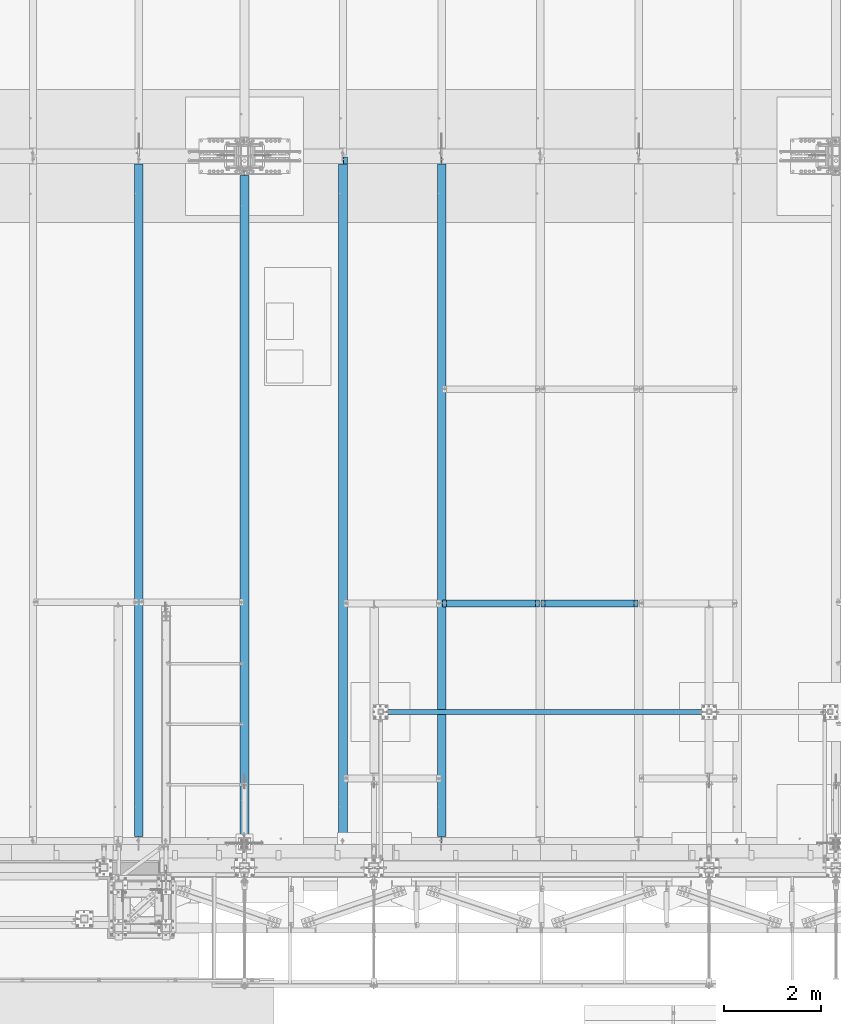
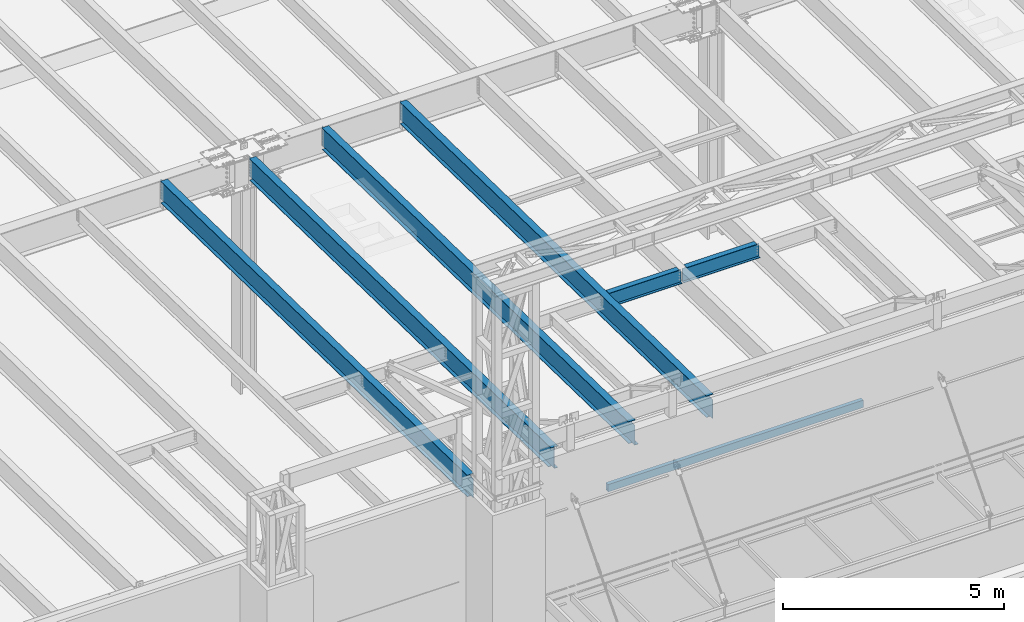
# One storey, part 1059 of 1763: 7 beams, 7 elements without a shape of their own.
"""IFC2X3 building model written with IfcOpenShell, lengths in millimetres."""

from ifc_helpers import new_model, si_unit, frame, origin_with_axes, place, context, subcontext, project, spatial, faceted_brep, material, type_object, element, aggregate, save


model = new_model("IFC2X3")

# Units and contexts
model_context = context("Model", 3, precision=1e-05, world=origin_with_axes())
body_context = subcontext(model_context, "Body", "Model", "MODEL_VIEW")
ifc_project = project(units=[si_unit("LENGTHUNIT", "METRE", prefix="MILLI"), si_unit("AREAUNIT", "SQUARE_METRE"), si_unit("VOLUMEUNIT", "CUBIC_METRE"), si_unit("MASSUNIT", "GRAM", prefix="KILO"), si_unit("TIMEUNIT", "SECOND"), si_unit("PLANEANGLEUNIT", "RADIAN"), si_unit("SOLIDANGLEUNIT", "STERADIAN"), si_unit("THERMODYNAMICTEMPERATUREUNIT", "DEGREE_CELSIUS"), si_unit("LUMINOUSINTENSITYUNIT", "LUMEN")], contexts=[model_context])

# Site, building, storey
site_placement = place(None, origin_with_axes())
site = spatial("IfcSite", under=ifc_project, at=site_placement, CompositionType="ELEMENT")
building_placement = place(site_placement, origin_with_axes())
building = spatial("IfcBuilding", under=site, at=building_placement, Name="Undefined", CompositionType="ELEMENT")
storey_placement = place(building_placement, origin_with_axes())
storey = spatial("IfcBuildingStorey", under=building, at=storey_placement, Name="Undefined", CompositionType="ELEMENT", Elevation=0.0)

# Assembly, beam
assembly_1_placement = place(storey_placement, origin_with_axes())
assembly_1 = element("IfcElementAssembly", 1, at=assembly_1_placement, inside=storey, Name="BEAM", AssemblyPlace="NOTDEFINED", PredefinedType="RIGID_FRAME")
ifc_material_1 = material(Name="STEEL/A992")
beam_type_1 = type_object("IfcBeamType", Name="W16X26", PredefinedType="NOTDEFINED")
beam_1_placement = place(assembly_1_placement, frame((-57530.4372736983, -8763.05542596541, 11901.1291231283), z_axis=(0.0, 0.0, 1.0), x_axis=(1.0, 0.0, 0.0)))
beam_1 = element("IfcBeam", 2, at=beam_1_placement, type_object=beam_type_1, material=ifc_material_1, Name="BEAM", ObjectType="W16X26", context=body_context, shape_type="Brep", body=[
    faceted_brep([(87.312500190732, -3.17499999999927, 161.665001675578), (87.312500190732, 3.17499999999927, 161.665001675578), (17.4624999999942, 3.17499999999927, 161.665001675578), (17.4624999999942, -3.17499999999927, 161.665001675578), (92.1725797087784, -3.17499999999927, 162.631731598165), (92.1725797087784, 3.17499999999927, 162.631731598165), (96.292756176932, -3.17499999999927, 165.384745498643), (96.292756176932, 3.17499999999927, 165.384745498643), (97.1527139056197, -3.17499999999927, 166.671763191049), (97.1527139056197, 3.17499999999927, 166.671763191049), (17.4625000000087, -3.17499999999927, -190.5), (17.4625000000087, -69.8500000000004, -190.5), (2014.53750000001, -69.8500000000004, -190.5), (2014.53750000001, -3.17499999999927, -190.5), (17.4625000000087, -69.8500000000004, -200.025), (2014.53750000001, -69.8500000000004, -200.025), (17.4625000000087, 69.8500000000004, -200.025), (2014.53750000001, 69.8500000000004, -200.025), (17.4625000000087, 69.8500000000004, -190.5), (2014.53750000001, 69.8500000000004, -190.5), (17.4625000000087, 3.17499999999927, -190.5), (2014.53750000001, 3.17499999999927, -190.5), (2014.53750000001, 3.17499999999927, 161.665001678701), (2014.53750000001, -3.17499999999927, 161.665001678701), (1944.68749980927, 3.17499999999927, 161.665001678701), (1944.68749980927, -3.17499999999927, 161.665001678701), (1939.82742029122, 3.17499999999927, 162.631731601288), (1939.82742029122, -3.17499999999927, 162.631731601288), (1935.70724382307, 3.17499999999927, 165.384745501766), (1935.70724382307, -3.17499999999927, 165.384745501766), (1934.84728609816, 3.17499999999927, 166.671763188517), (1934.84728609816, -3.17499999999927, 166.671763188517), (1934.11974687481, 3.17499999999927, 167.157889355802), (1934.11974687481, -3.17499999999927, 167.157889355802), (1931.36673297434, 3.17499999999927, 171.278065823955), (1931.36673297434, -3.17499999999927, 171.278065823955), (1930.40000305175, 3.17499999999927, 176.138145342002), (1930.40000305175, -3.17499999999927, 176.138145342002), (101.599996948236, 3.17499999999927, 190.5), (101.599996948236, 69.8500000000004, 190.5), (1930.40000305175, 69.8500000000004, 190.5), (1930.40000305175, 3.17499999999927, 190.5), (101.599996948236, -69.8500000000004, 200.025), (101.599996948236, -69.8500000000004, 190.5), (1930.40000305175, -69.8500000000004, 190.5), (1930.40000305175, -69.8500000000004, 200.025), (101.599996948236, 69.8500000000004, 200.025), (1930.40000305175, 69.8500000000004, 200.025), (1930.40000305175, -3.17499999999927, 190.5), (101.599996948236, -3.17499999999927, 190.5), (101.599996948236, 3.17499999999927, 176.138145342), (101.599996948236, -3.17499999999927, 176.138145342), (100.633267025645, 3.17499999999927, 171.278065823954), (100.633267025645, -3.17499999999927, 171.278065823954), (97.8802531251713, 3.17499999999927, 167.1578893558), (97.8802531251713, -3.17499999999927, 167.1578893558)], [[[0, 1, 2, 3]], [[4, 5, 1, 0]], [[6, 7, 5, 4]], [[8, 9, 7, 6]], [[10, 11, 12, 13]], [[11, 14, 15, 12]], [[14, 16, 17, 15]], [[16, 18, 19, 17]], [[18, 20, 21, 19]], [[13, 12, 15, 17, 19, 21, 22, 23]], [[23, 22, 24, 25]], [[25, 24, 26, 27]], [[27, 26, 28, 29]], [[29, 28, 30, 31]], [[32, 33, 31, 30]], [[33, 32, 34, 35]], [[35, 34, 36, 37]], [[38, 39, 40, 41]], [[42, 43, 44, 45]], [[46, 42, 45, 47]], [[39, 46, 47, 40]], [[45, 44, 48, 37, 36, 41, 40, 47]], [[43, 49, 48, 44]], [[42, 46, 39, 38, 50, 51, 49, 43]], [[51, 50, 52, 53]], [[53, 52, 54, 55]], [[4, 0, 3, 10, 13, 23, 25, 27, 29, 31, 33, 35, 37, 48, 49, 51, 53, 55, 8, 6]], [[20, 18, 16, 14, 11, 10, 3, 2]], [[54, 52, 50, 38, 41, 36, 34, 32, 30, 28, 26, 24, 22, 21, 20, 2, 1, 5, 7, 9]], [[55, 54, 9, 8]]]),
])
aggregate(assembly_1, [beam_1])

assembly_2_placement = place(storey_placement, origin_with_axes())
assembly_2 = element("IfcElementAssembly", 3, at=assembly_2_placement, inside=storey, Name="BEAM", AssemblyPlace="NOTDEFINED", PredefinedType="RIGID_FRAME")
beam_2_placement = place(assembly_2_placement, frame((-55498.4372736983, -8763.05542596541, 11901.1291231283), z_axis=(0.0, 0.0, 1.0), x_axis=(1.0, 0.0, 0.0)))
beam_2 = element("IfcBeam", 4, at=beam_2_placement, type_object=beam_type_1, material=ifc_material_1, Name="BEAM", ObjectType="W16X26", context=body_context, shape_type="Brep", body=[
    faceted_brep([(87.312500190732, -3.17499999999927, 161.665001675578), (87.312500190732, 3.17499999999927, 161.665001675578), (17.4624999999942, 3.17499999999927, 161.665001675578), (17.4624999999942, -3.17499999999927, 161.665001675578), (92.1725797087784, -3.17499999999927, 162.631731598165), (92.1725797087784, 3.17499999999927, 162.631731598165), (96.292756176932, -3.17499999999927, 165.384745498643), (96.292756176932, 3.17499999999927, 165.384745498643), (97.1527139056197, -3.17499999999927, 166.671763191049), (97.1527139056197, 3.17499999999927, 166.671763191049), (17.4625000000087, -3.17499999999927, -190.5), (17.4625000000087, -69.8500000000004, -190.5), (2014.53750000001, -69.8500000000004, -190.5), (2014.53750000001, -3.17499999999927, -190.5), (17.4625000000087, -69.8500000000004, -200.025), (2014.53750000001, -69.8500000000004, -200.025), (17.4625000000087, 69.8500000000004, -200.025), (2014.53750000001, 69.8500000000004, -200.025), (17.4625000000087, 69.8500000000004, -190.5), (2014.53750000001, 69.8500000000004, -190.5), (17.4625000000087, 3.17499999999927, -190.5), (2014.53750000001, 3.17499999999927, -190.5), (2014.53750000001, 3.17499999999927, 161.665001678701), (2014.53750000001, -3.17499999999927, 161.665001678701), (1944.68749980927, 3.17499999999927, 161.665001678701), (1944.68749980927, -3.17499999999927, 161.665001678701), (1939.82742029122, 3.17499999999927, 162.631731601288), (1939.82742029122, -3.17499999999927, 162.631731601288), (1935.70724382307, 3.17499999999927, 165.384745501766), (1935.70724382307, -3.17499999999927, 165.384745501766), (1934.84728609816, 3.17499999999927, 166.671763188517), (1934.84728609816, -3.17499999999927, 166.671763188517), (1934.11974687481, 3.17499999999927, 167.157889355802), (1934.11974687481, -3.17499999999927, 167.157889355802), (1931.36673297434, 3.17499999999927, 171.278065823955), (1931.36673297434, -3.17499999999927, 171.278065823955), (1930.40000305175, 3.17499999999927, 176.138145342002), (1930.40000305175, -3.17499999999927, 176.138145342002), (101.599996948236, 3.17499999999927, 190.5), (101.599996948236, 69.8500000000004, 190.5), (1930.40000305175, 69.8500000000004, 190.5), (1930.40000305175, 3.17499999999927, 190.5), (101.599996948236, -69.8500000000004, 200.025), (101.599996948236, -69.8500000000004, 190.5), (1930.40000305175, -69.8500000000004, 190.5), (1930.40000305175, -69.8500000000004, 200.025), (101.599996948236, 69.8500000000004, 200.025), (1930.40000305175, 69.8500000000004, 200.025), (1930.40000305175, -3.17499999999927, 190.5), (101.599996948236, -3.17499999999927, 190.5), (101.599996948236, 3.17499999999927, 176.138145342), (101.599996948236, -3.17499999999927, 176.138145342), (100.633267025645, 3.17499999999927, 171.278065823954), (100.633267025645, -3.17499999999927, 171.278065823954), (97.8802531251713, 3.17499999999927, 167.1578893558), (97.8802531251713, -3.17499999999927, 167.1578893558)], [[[0, 1, 2, 3]], [[4, 5, 1, 0]], [[6, 7, 5, 4]], [[8, 9, 7, 6]], [[10, 11, 12, 13]], [[11, 14, 15, 12]], [[14, 16, 17, 15]], [[16, 18, 19, 17]], [[18, 20, 21, 19]], [[13, 12, 15, 17, 19, 21, 22, 23]], [[23, 22, 24, 25]], [[25, 24, 26, 27]], [[27, 26, 28, 29]], [[29, 28, 30, 31]], [[32, 33, 31, 30]], [[33, 32, 34, 35]], [[35, 34, 36, 37]], [[38, 39, 40, 41]], [[42, 43, 44, 45]], [[46, 42, 45, 47]], [[39, 46, 47, 40]], [[45, 44, 48, 37, 36, 41, 40, 47]], [[43, 49, 48, 44]], [[42, 46, 39, 38, 50, 51, 49, 43]], [[51, 50, 52, 53]], [[53, 52, 54, 55]], [[4, 0, 3, 10, 13, 23, 25, 27, 29, 31, 33, 35, 37, 48, 49, 51, 53, 55, 8, 6]], [[20, 18, 16, 14, 11, 10, 3, 2]], [[54, 52, 50, 38, 41, 36, 34, 32, 30, 28, 26, 24, 22, 21, 20, 2, 1, 5, 7, 9]], [[55, 54, 9, 8]]]),
])
aggregate(assembly_2, [beam_2])

assembly_3_placement = place(storey_placement, origin_with_axes())
assembly_3 = element("IfcElementAssembly", 5, at=assembly_3_placement, inside=storey, Name="BEAM", AssemblyPlace="NOTDEFINED", PredefinedType="RIGID_FRAME")
ifc_material_2 = material()
beam_type_2 = type_object("IfcBeamType", Name="HSS8X4X3/8", PredefinedType="NOTDEFINED")
beam_3_placement = place(assembly_3_placement, frame((-58736.9367869337, -10998.2, 8521.70000000127), z_axis=(0.0, 0.0, 1.0), x_axis=(1.0, 0.0, 0.0)))
beam_3 = element("IfcBeam", 6, at=beam_3_placement, type_object=beam_type_2, material=ifc_material_2, Name="BEAM", ObjectType="HSS8X4X3/8", context=body_context, shape_type="Brep", body=[
    faceted_brep([(1.58750000000146, 41.2749999999996, -92.0750000000007), (1.58750000000146, -41.2749999999996, -92.0750000000007), (6665.91201281643, -41.2750000002816, -92.0750000000007), (6665.91201314648, 41.2749999997195, -92.0750000000007), (1.58750000000146, -41.2749999999996, 92.0750000000007), (6665.91201281643, -41.2750000002816, 92.0750000000007), (1.58750000000146, 41.2749999999996, 92.0750000000007), (6665.91201314648, 41.2749999997195, 92.0750000000007), (1.58750000000146, 50.7999999999993, -101.6), (1.58750000000146, 50.7999999999993, 101.6), (6665.91201318456, 50.7999999997191, 101.6), (6665.91201318456, 50.7999999997191, -101.6), (1.58750000000146, -50.7999999999993, 101.6), (6665.91201277835, -50.8000000002812, 101.6), (1.58750000000146, -50.7999999999993, -101.6), (6665.91201277835, -50.8000000002812, -101.6)], [[[0, 1, 2, 3]], [[1, 4, 5, 2]], [[4, 6, 7, 5]], [[6, 0, 3, 7]], [[8, 9, 10, 11]], [[9, 12, 13, 10]], [[12, 14, 15, 13]], [[14, 8, 11, 15]], [[13, 15, 11, 10], [5, 7, 3, 2]], [[14, 12, 9, 8], [6, 4, 1, 0]]]),
])
aggregate(assembly_3, [beam_3])

assembly_4_placement = place(storey_placement, origin_with_axes())
assembly_4 = element("IfcElementAssembly", 7, at=assembly_4_placement, inside=storey, Name="BEAM", AssemblyPlace="NOTDEFINED", PredefinedType="RIGID_FRAME")
beam_type_3 = type_object("IfcBeamType", Name="W24X55", PredefinedType="NOTDEFINED")
beam_4_placement = place(assembly_4_placement, frame((-57530.4372736983, -13722.2711313756, 11904.7280453544), z_axis=(0.0, 0.0209013539966291, 0.999781542838788), x_axis=(0.0, 0.999781542776098, -0.0209013569953182)))
beam_4 = element("IfcBeam", 8, at=beam_4_placement, type_object=beam_type_3, material=ifc_material_1, Name="BEAM", ObjectType="W24X55", context=body_context, shape_type="Brep", body=[
    faceted_brep([(14016.593893803, 4.76249999999709, -287.337500004851), (14016.593893803, 4.76238284193096, -300.037500004859), (14016.5938910267, 88.9000000000015, -300.037500004861), (14016.5938910267, 88.9000000000015, -287.337500004851), (14118.1827906951, 4.76299991607812, -300.037500004893), (14117.9172854725, 4.76249999999709, -287.337500004882), (165.102558712022, -4.76249999999709, -287.337500000289), (165.102558712022, -88.9000000000015, -287.337500000289), (14016.5938907292, -88.9000000000015, -287.337500004849), (14016.5938879523, -4.76249999999709, -287.337500004849), (153.198208143893, 4.76249999999709, 287.33750000018), (153.198208143893, 88.9000000000015, 287.33750000018), (14016.5938908944, 88.9000000000015, 287.33749999561), (14016.5938908944, 4.76249999999709, 287.33749999561), (153.198208143898, -88.9000000000015, 300.037500000191), (153.198208143898, 88.9000000000015, 300.037500000191), (153.198208143884, 4.76249999999709, 261.937499809663), (153.198208143884, -4.76249999999709, 261.937499809663), (153.198208143893, -4.76249999999709, 287.33750000018), (153.198208143893, -88.9000000000015, 287.33750000018), (152.50805080805, -4.76249999999709, 258.467844579442), (152.231478221292, 4.76249999999709, 257.077420291605), (152.231478221292, -4.76249999999709, 257.077420291605), (149.478464320808, 4.76249999999709, 252.957243823441), (149.478464320808, -4.76249999999709, 252.957243823441), (145.358287852643, 4.76249999999709, 250.204229922958), (145.358287852643, -4.76249999999709, 250.204229922958), (140.498208334584, 4.76249999999709, 249.237500000372), (140.498208334584, -4.76249999999709, 249.237500000372), (20.9102290337687, 4.76249999999709, 249.23750000041), (20.9102290337687, -4.76249999999709, 249.23750000041), (31.9459431613013, 4.76249999999709, -278.637500001068), (31.9459431613013, -4.76249999999709, -278.637500001068), (153.198208334481, 4.76249999999709, -278.637500001108), (153.198208334481, -4.76249999999709, -278.637500001108), (158.058287852537, 4.76249999999709, -279.6042299237), (158.058287852537, -4.76249999999709, -279.6042299237), (162.178464320699, 4.76249999999709, -282.357243824186), (162.178464320699, -4.76249999999709, -282.357243824186), (163.867339899425, -4.76249999999709, -284.884824747733), (164.93147822118, 4.76249999999709, -286.477420292351), (164.93147822118, -4.76249999999709, -286.477420292351), (165.102558712022, 4.76249999999709, -287.337500000289), (165.102558712022, 88.9000000000015, -287.337500000289), (165.89820814377, 88.9000000000015, -291.337499810408), (165.89820814377, -88.9000000000015, -291.337499810408), (165.898208143768, 88.9000000000015, -300.037500000297), (165.898208143768, -88.9000000000015, -300.037500000297), (14016.5938907292, -88.9000000000015, -300.037500004861), (14016.5938879524, -4.76262320829846, -300.037500004861), (14118.182790722, -4.76200008393062, -300.037500004893), (14117.9172854725, -4.76249999999709, -287.337500004882), (14168.9938907729, -4.76200008393062, -300.03750000491), (14168.7283855234, -4.76249999999709, -287.3375000049), (14168.993890746, 4.76299991607812, -300.03750000491), (14168.7283855234, 4.76249999999709, -287.3375000049), (14168.3301609801, -4.76249999999709, -268.289092414178), (14168.3301647496, 4.76249999999709, -268.289272721053), (14157.6435424792, 4.76249999999709, 242.887499877306), (14157.6435424792, -4.76249999999709, 242.887499877306), (14024.4338111857, -4.76249999999709, 243.854229799896), (14020.3136347175, -4.76249999999709, 246.607243700379), (14017.560620817, -4.76249999999709, 250.727420168543), (14016.5938908944, -4.76249999999709, 255.5874996866), (14016.5938908944, -4.76249999999709, 287.33749999561), (14029.2938907037, -4.76249999999709, 242.887499877303), (14016.5938908944, -88.9000000000015, 287.33749999561), (14016.5938908944, -88.9000000000015, 300.037499995622), (14016.5938908944, 88.9000000000015, 300.037499995622), (14016.5938908944, 4.76249999999709, 255.5874996866), (14017.560620817, 4.76249999999709, 250.727420168543), (14020.3136347175, 4.76249999999709, 246.607243700379), (14024.4338111857, 4.76249999999709, 243.854229799896), (14029.2938907037, 4.76249999999709, 242.887499877303)], [[[0, 1, 2, 3]], [[4, 1, 0, 5]], [[6, 7, 8, 9]], [[10, 11, 12, 13]], [[14, 15, 11, 10, 16, 17, 18, 19]], [[20, 17, 16, 21, 22]], [[22, 21, 23, 24]], [[24, 23, 25, 26]], [[26, 25, 27, 28]], [[28, 27, 29, 30]], [[30, 29, 31, 32]], [[32, 31, 33, 34]], [[34, 33, 35, 36]], [[36, 35, 37, 38]], [[39, 38, 37, 40, 41]], [[7, 6, 41, 40, 42, 43, 44, 45]], [[45, 44, 46, 47]], [[7, 45, 47, 48, 8]], [[8, 48, 49, 9]], [[50, 51, 9, 49]], [[52, 53, 51, 50]], [[54, 4, 5, 55]], [[56, 53, 52, 54, 55, 57, 58, 59]], [[60, 61, 62, 63, 64, 18, 17, 20, 22, 24, 26, 28, 30, 32, 34, 36, 38, 39, 41, 6, 9, 51, 53, 56, 59, 65]], [[19, 18, 64, 66]], [[14, 19, 66, 67]], [[15, 14, 67, 68]], [[11, 15, 68, 12]], [[67, 66, 64, 63, 69, 13, 12, 68]], [[62, 70, 69, 63]], [[61, 71, 70, 62]], [[60, 72, 71, 61]], [[65, 73, 72, 60]], [[59, 58, 73, 65]], [[57, 55, 5, 0, 42, 40, 37, 35, 33, 31, 29, 27, 25, 23, 21, 16, 10, 13, 69, 70, 71, 72, 73, 58]], [[43, 42, 0, 3]], [[46, 44, 43, 3, 2]], [[54, 52, 50, 49, 48, 47, 46, 2, 1, 4]]]),
])
aggregate(assembly_4, [beam_4])

assembly_5_placement = place(storey_placement, origin_with_axes())
assembly_5 = element("IfcElementAssembly", 9, at=assembly_5_placement, inside=storey, Name="BEAM", AssemblyPlace="NOTDEFINED", PredefinedType="RIGID_FRAME")
beam_5_placement = place(assembly_5_placement, frame((-59562.4372736983, -13722.2711313756, 11904.7280453544), z_axis=(0.0, 0.0209013539966291, 0.999781542838788), x_axis=(0.0, 0.999781542776098, -0.0209013569953182)))
beam_5 = element("IfcBeam", 10, at=beam_5_placement, type_object=beam_type_3, material=ifc_material_1, Name="BEAM", ObjectType="W24X55", context=body_context, shape_type="Brep", body=[
    faceted_brep([(14016.6713189086, 5.06262333965424, -287.337500004851), (14016.6713189087, 5.06237371335737, -300.037500004863), (14016.6713136267, 88.9000000000015, -300.037500004863), (14016.6713136267, 88.9000000000015, -287.337500004851), (14067.3716906706, 5.0625, -300.037500004877), (14067.1061854479, 5.0625, -287.337500004867), (140.42076922026, -4.76249999999709, 248.977501678848), (140.42076922026, 4.76249999999709, 248.977501678848), (20.9156645386702, 4.76249999999709, 248.977501678888), (20.9156645386702, -4.76249999999709, 248.977501678888), (145.280848738317, -4.76249999999709, 249.944231601437), (145.280848738317, 4.76249999999709, 249.944231601437), (149.401025206482, -4.76249999999709, 252.697245501922), (149.401025206482, 4.76249999999709, 252.697245501922), (152.15403910697, -4.76249999999709, 256.817421970085), (152.15403910697, 4.76249999999709, 256.817421970085), (153.12076902956, -4.76249999999709, 261.67750148814), (153.12076902956, 4.76249999999709, 261.67750148814), (153.120769029574, -88.9000000000015, 300.03750000019), (153.120769029574, 88.9000000000015, 300.03750000019), (153.120769029569, 88.9000000000015, 287.33750000018), (153.120769029569, 4.76249999999709, 287.33750000018), (153.120769029569, -4.76249999999709, 287.33750000018), (153.120769029569, -88.9000000000015, 287.33750000018), (14016.6713298856, 88.9000000000015, 287.33749999561), (14016.6713298856, 4.76249999999709, 287.33749999561), (14168.7283855234, 4.76249999999709, -287.3375000049), (32.1278246917773, 4.76249999999709, -287.337500000243), (14016.6713298856, 4.76249999999709, 255.327497550523), (14017.6380598082, 4.76249999999709, 250.467418032464), (14020.3910737087, 4.76249999999709, 246.347241564303), (14024.5112501769, 4.76249999999709, 243.594227663818), (14029.3713296949, 4.76249999999709, 242.627497741227), (14157.648978064, 4.76249999999709, 242.627497741229), (153.120588301108, 88.9000000000015, -287.337500000282), (153.120588301104, 88.9000000000015, -300.037500000293), (153.120599954549, 5.06262326912838, -300.037500000293), (153.120599954584, 5.06237364569824, -287.337500000282), (32.3933299144519, 5.06260648809985, -300.037500000253), (32.1278246917773, 5.06235682772967, -287.337500000243), (32.3933299144519, -88.9000000000015, -300.037500000253), (32.1278246917773, -88.9000000000015, -287.337500000243), (32.1278246917773, -4.76249999999709, -287.337500000243), (14168.9938907462, -88.9000000000015, -300.03750000491), (14168.7283855236, -88.9000000000015, -287.3375000049), (14168.7283855234, -4.76249999999709, -287.3375000049), (14024.5112501769, -4.76249999999709, 243.594227663818), (14020.3910737087, -4.76249999999709, 246.347241564303), (14017.6380598082, -4.76249999999709, 250.467418032464), (14016.6713298856, -4.76249999999709, 255.327497550523), (14016.6713298856, -4.76249999999709, 287.33749999561), (14157.648978064, -4.76249999999709, 242.627497741229), (14029.3713296949, -4.76249999999709, 242.627497741227), (14016.6713298856, -88.9000000000015, 287.33749999561), (14016.6713298856, -88.9000000000015, 300.03749999562), (14016.6713298856, 88.9000000000015, 300.03749999562), (14168.9938907729, 5.0625, -300.03750000491), (14168.7283855502, 5.0625, -287.3375000049)], [[[0, 1, 2, 3]], [[4, 1, 0, 5]], [[6, 7, 8, 9]], [[10, 11, 7, 6]], [[12, 13, 11, 10]], [[14, 15, 13, 12]], [[16, 17, 15, 14]], [[18, 19, 20, 21, 17, 16, 22, 23]], [[21, 20, 24, 25]], [[26, 27, 8, 7, 11, 13, 15, 17, 21, 25, 28, 29, 30, 31, 32, 33]], [[34, 35, 36, 37]], [[37, 36, 38, 39]], [[40, 41, 42, 9, 8, 27, 39, 38]], [[41, 40, 43, 44]], [[42, 41, 44, 45]], [[46, 47, 48, 49, 50, 22, 16, 14, 12, 10, 6, 9, 42, 45, 51, 52]], [[23, 22, 50, 53]], [[18, 23, 53, 54]], [[19, 18, 54, 55]], [[20, 19, 55, 24]], [[54, 53, 50, 49, 28, 25, 24, 55]], [[48, 29, 28, 49]], [[47, 30, 29, 48]], [[46, 31, 30, 47]], [[52, 32, 31, 46]], [[51, 33, 32, 52]], [[45, 44, 43, 56, 57, 26, 33, 51]], [[56, 4, 5, 57]], [[3, 34, 37, 39, 27, 26, 57, 5, 0]], [[35, 34, 3, 2]], [[56, 43, 40, 38, 36, 35, 2, 1, 4]]]),
])
aggregate(assembly_5, [beam_5])

assembly_6_placement = place(storey_placement, origin_with_axes())
assembly_6 = element("IfcElementAssembly", 11, at=assembly_6_placement, inside=storey, Name="BEAM", AssemblyPlace="NOTDEFINED", PredefinedType="RIGID_FRAME")
beam_6_placement = place(assembly_6_placement, frame((-61594.4372736983, -13722.2710091131, 11904.7280453511), z_axis=(0.0, 0.0209013539966291, 0.999781542838788), x_axis=(0.0, 0.999781542776098, -0.0209013569953182)))
beam_6 = element("IfcBeam", 12, at=beam_6_placement, type_object=beam_type_3, material=ifc_material_1, Name="BEAM", ObjectType="W24X55", context=body_context, shape_type="Brep", body=[
    faceted_brep([(13780.8771679396, 5.06261017911311, -287.337500004773), (13780.8771679399, 5.06238689332531, -300.037500004781), (13780.8770768085, 88.9000000000015, -300.037500004782), (13780.8770768085, 88.9000000000015, -287.337500004771), (13939.5498908057, 5.06255937039532, -300.037500004833), (13939.2843856719, 5.06278236756043, -287.337500004824), (139.995848836421, 4.76249999999709, 287.337500000187), (139.995848836421, 88.9000000000015, 287.337500000187), (13780.8773320447, 88.9000000000015, 287.33749999569), (13780.8773320447, 4.76249999999709, 287.33749999569), (13939.2843856719, -4.76249999999709, -287.337500004824), (152.009960162448, -4.76249999999709, -287.33750000028), (152.009960162448, -88.9000000000015, -287.33750000028), (13780.8773266078, -88.9000000000015, -287.337500004771), (13780.8772354767, -5.06238681420655, -287.337500004773), (13939.2843856719, -5.06221462566464, -287.337500004824), (13788.7172523359, -4.76249999999709, 249.944231589639), (13784.5970758677, -4.76249999999709, 252.697245490122), (13781.8440619673, -4.76249999999709, 256.817421958287), (13780.8773320447, -4.76249999999709, 261.677501476344), (13780.8773320447, -4.76249999999709, 287.33749999569), (139.995848836421, -4.76249999999709, 287.337500000187), (13928.0722292748, -4.76249999999709, 248.97750166705), (13793.577331854, -4.76249999999709, 248.977501667048), (139.995848836421, -88.9000000000015, 287.337500000187), (13780.8773320447, -88.9000000000015, 287.33749999569), (139.730343613746, -88.9000000000015, 300.037500000195), (13780.8773320447, -88.9000000000015, 300.0374999957), (139.730343613746, 88.9000000000015, 300.037500000195), (13780.8773320447, 88.9000000000015, 300.0374999957), (13780.8773320447, 4.76249999999709, 261.677501476344), (13781.8440619673, 4.76249999999709, 256.817421958287), (13784.5970758677, 4.76249999999709, 252.697245490122), (13788.7172523359, 4.76249999999709, 249.944231589639), (13793.577331854, 4.76249999999709, 248.977501667048), (13928.0722292748, 4.76249999999709, 248.97750166705), (13939.2843856719, 4.76249999999709, -287.337500004824), (152.009960162448, 4.76249999999709, -287.33750000028), (273.002908370619, 88.9000000000015, -287.33750000032), (273.002908370616, 88.9000000000015, -300.037500000331), (273.002973260362, 5.06262327161676, -300.03750000033), (273.002973260556, 5.06237365160632, -287.33750000032), (152.275465385123, 5.06252982856677, -300.037500000291), (152.009960162448, 5.06228000308329, -287.33750000028), (152.275465385123, -88.9000000000015, -300.037500000291), (13780.8773266078, -88.9000000000015, -300.037500004782), (13780.8772354769, -5.06261009999434, -300.037500004782), (13939.5498908057, -5.06243762282975, -300.037500004833)], [[[0, 1, 2, 3]], [[4, 1, 0, 5]], [[6, 7, 8, 9]], [[10, 11, 12, 13, 14, 15]], [[16, 17, 18, 19, 20, 21, 11, 10, 22, 23]], [[24, 21, 20, 25]], [[26, 24, 25, 27]], [[28, 26, 27, 29]], [[7, 28, 29, 8]], [[27, 25, 20, 19, 30, 9, 8, 29]], [[18, 31, 30, 19]], [[17, 32, 31, 18]], [[16, 33, 32, 17]], [[23, 34, 33, 16]], [[22, 35, 34, 23]], [[36, 37, 6, 9, 30, 31, 32, 33, 34, 35]], [[38, 39, 40, 41]], [[41, 40, 42, 43]], [[44, 12, 11, 21, 24, 26, 28, 7, 6, 37, 43, 42]], [[12, 44, 45, 13]], [[13, 45, 46, 14]], [[47, 15, 14, 46]], [[36, 35, 22, 10, 15, 47, 4, 5]], [[3, 38, 41, 43, 37, 36, 5, 0]], [[39, 38, 3, 2]], [[47, 46, 45, 44, 42, 40, 39, 2, 1, 4]]]),
])
aggregate(assembly_6, [beam_6])

assembly_7_placement = place(storey_placement, origin_with_axes())
assembly_7 = element("IfcElementAssembly", 13, at=assembly_7_placement, inside=storey, Name="BEAM", AssemblyPlace="NOTDEFINED", PredefinedType="RIGID_FRAME")
beam_7_placement = place(assembly_7_placement, frame((-63773.7572736983, -13722.2711313756, 11904.7280453544), z_axis=(0.0, 0.0209013539966291, 0.999781542838788), x_axis=(0.0, 0.999781542776098, -0.0209013569953182)))
beam_7 = element("IfcBeam", 14, at=beam_7_placement, type_object=beam_type_3, material=ifc_material_1, Name="BEAM", ObjectType="W24X55", context=body_context, shape_type="Brep", body=[
    faceted_brep([(14016.593893803, 4.76249999999709, -287.337500004851), (14016.593893803, 4.76238284193096, -300.037500004859), (14016.5938910267, 88.9000000000015, -300.037500004861), (14016.5938910267, 88.9000000000015, -287.337500004851), (14118.1827906951, 4.76299991607812, -300.037500004893), (14117.9172854725, 4.76249999999709, -287.337500004882), (165.102558712022, -4.76249999999709, -287.337500000289), (165.102558712022, -88.9000000000015, -287.337500000289), (14016.5938907292, -88.9000000000015, -287.337500004849), (14016.5938879523, -4.76249999999709, -287.337500004849), (153.198208143893, 4.76249999999709, 287.33750000018), (153.198208143893, 88.9000000000015, 287.33750000018), (14016.5938908944, 88.9000000000015, 287.33749999561), (14016.5938908944, 4.76249999999709, 287.33749999561), (153.198208143898, -88.9000000000015, 300.037500000191), (153.198208143898, 88.9000000000015, 300.037500000191), (153.198208143884, 4.76249999999709, 261.937499809663), (153.198208143884, -4.76249999999709, 261.937499809663), (153.198208143893, -4.76249999999709, 287.33750000018), (153.198208143893, -88.9000000000015, 287.33750000018), (152.50805080805, -4.76249999999709, 258.467844579442), (152.231478221292, 4.76249999999709, 257.077420291605), (152.231478221292, -4.76249999999709, 257.077420291605), (149.478464320808, 4.76249999999709, 252.957243823441), (149.478464320808, -4.76249999999709, 252.957243823441), (145.358287852643, 4.76249999999709, 250.204229922958), (145.358287852643, -4.76249999999709, 250.204229922958), (140.498208334584, 4.76249999999709, 249.237500000372), (140.498208334584, -4.76249999999709, 249.237500000372), (20.9102290337687, 4.76249999999709, 249.23750000041), (20.9102290337687, -4.76249999999709, 249.23750000041), (31.9459431613013, 4.76249999999709, -278.637500001068), (31.9459431613013, -4.76249999999709, -278.637500001068), (153.198208334481, 4.76249999999709, -278.637500001108), (153.198208334481, -4.76249999999709, -278.637500001108), (158.058287852537, 4.76249999999709, -279.6042299237), (158.058287852537, -4.76249999999709, -279.6042299237), (162.178464320699, 4.76249999999709, -282.357243824186), (162.178464320699, -4.76249999999709, -282.357243824186), (163.867339899425, -4.76249999999709, -284.884824747733), (164.93147822118, 4.76249999999709, -286.477420292351), (164.93147822118, -4.76249999999709, -286.477420292351), (165.102558712022, 4.76249999999709, -287.337500000289), (165.102558712022, 88.9000000000015, -287.337500000289), (165.89820814377, 88.9000000000015, -291.337499810408), (165.89820814377, -88.9000000000015, -291.337499810408), (165.898208143768, 88.9000000000015, -300.037500000297), (165.898208143768, -88.9000000000015, -300.037500000297), (14016.5938907292, -88.9000000000015, -300.037500004861), (14016.5938879524, -4.76262320829846, -300.037500004861), (14118.182790722, -4.76200008393062, -300.037500004893), (14117.9172854725, -4.76249999999709, -287.337500004882), (14168.9938907729, -4.76200008393062, -300.03750000491), (14168.7283855234, -4.76249999999709, -287.3375000049), (14168.993890746, 4.76299991607812, -300.03750000491), (14168.7283855234, 4.76249999999709, -287.3375000049), (14168.3301609801, -4.76249999999709, -268.289092414178), (14168.3301647496, 4.76249999999709, -268.289272721053), (14157.6435424792, 4.76249999999709, 242.887499877306), (14157.6435424792, -4.76249999999709, 242.887499877306), (14024.4338111857, -4.76249999999709, 243.854229799896), (14020.3136347175, -4.76249999999709, 246.607243700379), (14017.560620817, -4.76249999999709, 250.727420168543), (14016.5938908944, -4.76249999999709, 255.5874996866), (14016.5938908944, -4.76249999999709, 287.33749999561), (14029.2938907037, -4.76249999999709, 242.887499877303), (14016.5938908944, -88.9000000000015, 287.33749999561), (14016.5938908944, -88.9000000000015, 300.037499995622), (14016.5938908944, 88.9000000000015, 300.037499995622), (14016.5938908944, 4.76249999999709, 255.5874996866), (14017.560620817, 4.76249999999709, 250.727420168543), (14020.3136347175, 4.76249999999709, 246.607243700379), (14024.4338111857, 4.76249999999709, 243.854229799896), (14029.2938907037, 4.76249999999709, 242.887499877303)], [[[0, 1, 2, 3]], [[4, 1, 0, 5]], [[6, 7, 8, 9]], [[10, 11, 12, 13]], [[14, 15, 11, 10, 16, 17, 18, 19]], [[20, 17, 16, 21, 22]], [[22, 21, 23, 24]], [[24, 23, 25, 26]], [[26, 25, 27, 28]], [[28, 27, 29, 30]], [[30, 29, 31, 32]], [[32, 31, 33, 34]], [[34, 33, 35, 36]], [[36, 35, 37, 38]], [[39, 38, 37, 40, 41]], [[7, 6, 41, 40, 42, 43, 44, 45]], [[45, 44, 46, 47]], [[7, 45, 47, 48, 8]], [[8, 48, 49, 9]], [[50, 51, 9, 49]], [[52, 53, 51, 50]], [[54, 4, 5, 55]], [[56, 53, 52, 54, 55, 57, 58, 59]], [[60, 61, 62, 63, 64, 18, 17, 20, 22, 24, 26, 28, 30, 32, 34, 36, 38, 39, 41, 6, 9, 51, 53, 56, 59, 65]], [[19, 18, 64, 66]], [[14, 19, 66, 67]], [[15, 14, 67, 68]], [[11, 15, 68, 12]], [[67, 66, 64, 63, 69, 13, 12, 68]], [[62, 70, 69, 63]], [[61, 71, 70, 62]], [[60, 72, 71, 61]], [[65, 73, 72, 60]], [[59, 58, 73, 65]], [[57, 55, 5, 0, 42, 40, 37, 35, 33, 31, 29, 27, 25, 23, 21, 16, 10, 13, 69, 70, 71, 72, 73, 58]], [[43, 42, 0, 3]], [[46, 44, 43, 3, 2]], [[54, 52, 50, 49, 48, 47, 46, 2, 1, 4]]]),
])
aggregate(assembly_7, [beam_7])

save(model, "model.ifc")
